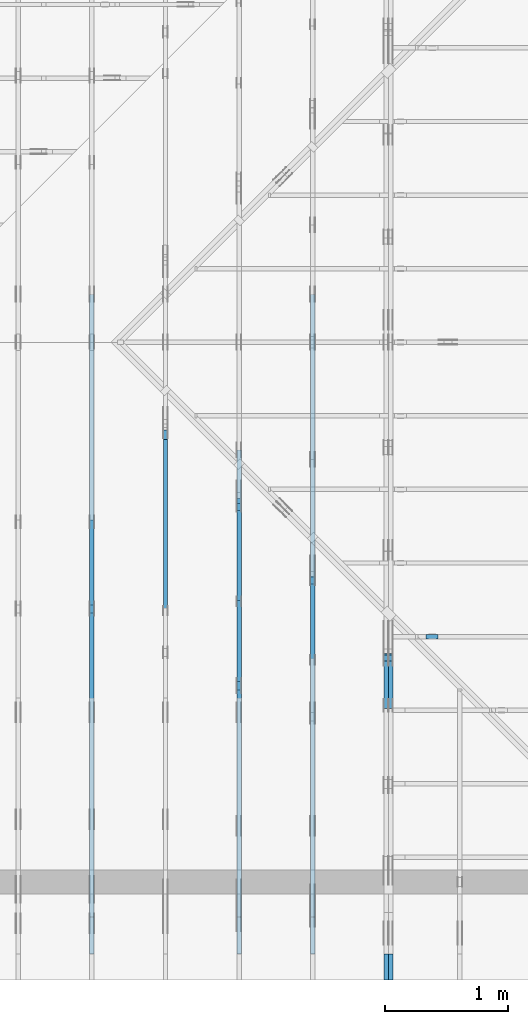
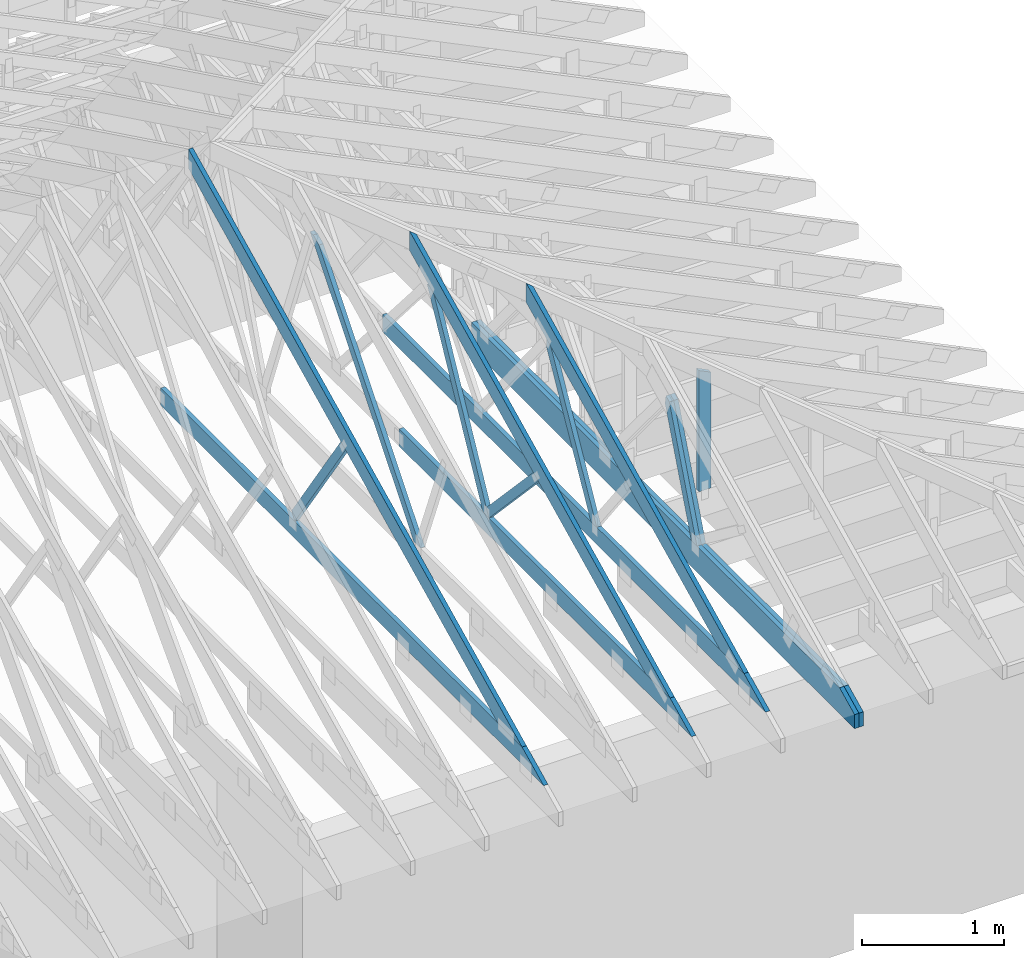
# One storey, part 29 of 159: 16 members, 6 elements without a shape of their own.
"""IFC2X3 building model written with IfcOpenShell, lengths in millimetres."""

from ifc_helpers import new_model, si_unit, frame, origin, origin_with_axes, origin_2d, place, context, project, spatial, faceted_brep, element, aggregate, save


model = new_model("IFC2X3")

# Units and contexts
model_context = context("Model", 3, precision=1e-05, world=origin())
plan_context = context("Plan", 2, precision=1e-05, world=origin_2d())
ifc_project = project(units=[si_unit("LENGTHUNIT", "METRE", prefix="MILLI"), si_unit("AREAUNIT", "SQUARE_METRE"), si_unit("VOLUMEUNIT", "CUBIC_METRE"), si_unit("SOLIDANGLEUNIT", "STERADIAN"), si_unit("PLANEANGLEUNIT", "RADIAN"), si_unit("MASSUNIT", "GRAM"), si_unit("TIMEUNIT", "SECOND"), si_unit("THERMODYNAMICTEMPERATUREUNIT", "DEGREE_CELSIUS"), si_unit("LUMINOUSINTENSITYUNIT", "LUMEN")], contexts=[model_context, plan_context])

# Site, building, storey
site_placement = place(None, origin_with_axes())
site = spatial("IfcSite", under=ifc_project, at=site_placement, CompositionType="ELEMENT")
building_placement = place(site_placement, origin_with_axes())
building = spatial("IfcBuilding", under=site, at=building_placement, Name="Plan 1", CompositionType="ELEMENT")
storey_placement = place(building_placement, origin_with_axes())
storey = spatial("IfcBuildingStorey", under=building, at=storey_placement, Name="Etasje 1", CompositionType="ELEMENT", Elevation=0.0)

# Assembly, member
assembly_1_placement = place(storey_placement, frame((16311.022261404749, -699.9989301294839, 1.1021457184401395e-15), z_axis=(1.0, -6.123031769111886e-17, 6.123031769111886e-17), x_axis=(6.123031769111886e-17, 1.0, 0.0)))
assembly_1 = element("IfcElementAssembly", 1, at=assembly_1_placement, inside=storey, Name="V8 (33)", AssemblyPlace="FACTORY", PredefinedType="TRUSS")
member_1_placement = place(assembly_1_placement, frame((4476.480509805102, 2189.4895238358513, -36.0), z_axis=(0.0, 0.0, 1.0), x_axis=(-0.6357240016981588, -0.7719164421521797, 0.0)))
member_1 = element("IfcMember", 2, at=member_1_placement, Name="V8-D11", context=model_context, shape_type="Brep", body=[
    faceted_brep([(2295.6910328957492, 73.00002724191063, 36.0), (0.0, 73.00002724191063, 36.0), (30.060308752172205, 36.5000129350874, 36.0), (110.05477702588541, 8.645112211524975e-05, 36.0), (2355.8113399879844, 8.645112211524975e-05, 36.0), (0.0, 73.00002724191063, 0.0), (2295.6910328957492, 73.00002724191063, 2.8113178252971904e-13), (2355.8113399879844, 8.645112211524975e-05, 2.8849415353560944e-13), (110.05477702588541, 8.645112211524975e-05, 1.3477377921440427e-14), (30.060308752172205, 36.5000129350874, 3.68120450957725e-15), (30.060242122563075, 36.50000000000318, -7.888609052210118e-31), (30.06024212256308, 36.50000000000319, 36.0), (8.950125995710323e-05, 73.00000000001138, 36.0), (8.950125995710323e-05, 73.00000000001138, -1.5777218104420236e-30), (110.05486615064636, 9.968914582714206e-12, 2.7610131682735413e-30), (110.05486615064636, 9.968914582714206e-12, 36.0), (30.06024212256306, 36.500000000003176, 36.0), (30.06024212256306, 36.500000000003176, 7.888609052210118e-31), (2355.811360573849, 1.6924518967404314e-12, -1.0362936731435327e-28), (2355.811360573849, 1.6946561881773117e-12, 36.0), (110.05486615064638, 1.0085711156000963e-11, 36.0), (110.05486615064638, 1.0083506864564083e-11, -4.84118395043281e-30), (2295.6910553312528, 73.00000000000455, 0.0), (2295.6910553312528, 73.00000000000455, 36.0), (2355.8113605738495, 0.0, 36.0), (2355.8113605738495, 0.0, 1.262177448353619e-29), (8.950125993578695e-05, 73.00000000001137, 0.0), (8.950125993578695e-05, 73.00000000001137, 36.0), (2295.6910553312523, 73.0000000000046, 36.0), (2295.6910553312523, 73.0000000000046, 3.1554436208840472e-30)], [[[0, 1, 2, 3, 4]], [[5, 6, 7, 8, 9]], [[10, 11, 12, 13]], [[14, 15, 16, 17]], [[18, 19, 20, 21]], [[22, 23, 24, 25]], [[26, 27, 28, 29]]]),
])
aggregate(assembly_1, [member_1])

# Assembly, members
assembly_2_placement = place(storey_placement, frame((18074.541652722903, -699.9989301294845, 4.408582873760558e-15), z_axis=(-1.0, 1.836909530733566e-16, 6.123031769111886e-17), x_axis=(-1.836909530733566e-16, -1.0, 0.0)))
assembly_2 = element("IfcElementAssembly", 3, at=assembly_2_placement, inside=storey, Name="V5 (30)", AssemblyPlace="FACTORY", PredefinedType="TRUSS")
member_2_placement = place(assembly_2_placement, frame((2.1736789885403288e-14, 222.99999999999997, -36.0), z_axis=(0.0, 0.0, 1.0), x_axis=(-1.0, 1.2246063538223773e-16, 0.0)))
member_2 = element("IfcMember", 4, at=member_2_placement, Name="V5-U2", context=model_context, shape_type="Brep", body=[
    faceted_brep([(5380.0, 223.00000000000125, 36.0), (0.0, 223.00000000000125, 36.0), (2.876229701544728e-05, 102.99998474121091, 36.0), (211.1812896728516, 0.0, 36.0), (5380.0, 0.0, 36.0), (0.0, 223.00000000000125, 0.0), (5380.0, 223.00000000000125, 6.58838218356439e-13), (5380.0, 0.0, 6.58838218356439e-13), (211.1812896728516, 0.0, 2.5861394914177804e-14), (2.876229701544728e-05, 102.99998474121091, 3.522249167564314e-21), (2.8762297051813242e-05, 102.9999859710806, -2.5591602876158762e-30), (2.8762297054017533e-05, 102.9999859710806, 36.0), (9.269391217049325e-14, 223.00000000001455, 36.0), (9.048962073361297e-14, 223.00000000001455, -5.540707857007639e-30), (211.18129568360746, -7.105427357601002e-14, 4.733165431326071e-30), (211.18129568360746, -7.105427357601002e-14, 36.0), (2.876229702053479e-05, 102.9999859710806, 36.0), (2.876229702053479e-05, 102.9999859710806, -1.5777218104420236e-30), (5380.0, -1.039350988528013e-12, 1.4021168432107416e-28), (5380.0, -1.0371466970911327e-12, 36.0), (211.1812956836075, -8.768146303186246e-14, 36.0), (211.1812956836075, -8.988575446874274e-14, 5.5037333020270255e-30), (5380.0, 223.00000000000125, 0.0), (5380.0, 223.00000000000125, 36.0), (5380.0, 1.2505552149377763e-12, 36.0), (5380.0, 1.2505552149377763e-12, 0.0), (0.0, 223.00000000001452, 0.0), (0.0, 223.00000000001452, 36.0), (5380.0, 223.00000000000105, 36.0), (5380.0, 223.00000000000105, -1.262177448353619e-29)], [[[0, 1, 2, 3, 4]], [[5, 6, 7, 8, 9]], [[10, 11, 12, 13]], [[14, 15, 16, 17]], [[18, 19, 20, 21]], [[22, 23, 24, 25]], [[26, 27, 28, 29]]]),
])
member_3_placement = place(assembly_2_placement, frame((2.1736789885403288e-14, 222.99999999999997, -72.0), z_axis=(0.0, 0.0, 1.0), x_axis=(-1.0, 1.2246063538223773e-16, 0.0)))
member_3 = element("IfcMember", 5, at=member_3_placement, Name="V5-U2", context=model_context, shape_type="Brep", body=[
    faceted_brep([(5380.0, 223.00000000000125, 36.0), (0.0, 223.00000000000125, 36.0), (2.876229701544728e-05, 102.99998474121091, 36.0), (211.1812896728516, 0.0, 36.0), (5380.0, 0.0, 36.0), (0.0, 223.00000000000125, 0.0), (5380.0, 223.00000000000125, 6.58838218356439e-13), (5380.0, 0.0, 6.58838218356439e-13), (211.1812896728516, 0.0, 2.5861394914177804e-14), (2.876229701544728e-05, 102.99998474121091, 3.522249167564314e-21), (2.8762297051813242e-05, 102.9999859710806, -2.5591602876158762e-30), (2.8762297054017533e-05, 102.9999859710806, 36.0), (9.269391217049325e-14, 223.00000000001455, 36.0), (9.048962073361297e-14, 223.00000000001455, -5.540707857007639e-30), (211.18129568360746, -7.105427357601002e-14, 4.733165431326071e-30), (211.18129568360746, -7.105427357601002e-14, 36.0), (2.876229702053479e-05, 102.9999859710806, 36.0), (2.876229702053479e-05, 102.9999859710806, -1.5777218104420236e-30), (5380.0, -1.039350988528013e-12, 1.4021168432107416e-28), (5380.0, -1.0371466970911327e-12, 36.0), (211.1812956836075, -8.768146303186246e-14, 36.0), (211.1812956836075, -8.988575446874274e-14, 5.5037333020270255e-30), (5380.0, 223.00000000000125, 0.0), (5380.0, 223.00000000000125, 36.0), (5380.0, 1.2505552149377763e-12, 36.0), (5380.0, 1.2505552149377763e-12, 0.0), (0.0, 223.00000000001452, 0.0), (0.0, 223.00000000001452, 36.0), (5380.0, 223.00000000000105, 36.0), (5380.0, 223.00000000000105, -1.262177448353619e-29)], [[[0, 1, 2, 3, 4]], [[5, 6, 7, 8, 9]], [[10, 11, 12, 13]], [[14, 15, 16, 17]], [[18, 19, 20, 21]], [[22, 23, 24, 25]], [[26, 27, 28, 29]]]),
])
member_4_placement = place(assembly_2_placement, frame((-2684.061344967092, 1234.6539427070286, -36.0), z_axis=(0.0, 0.0, 1.0), x_axis=(0.3612308951570343, -0.9324764020521097, 0.0)))
member_4 = element("IfcMember", 6, at=member_4_placement, Name="V5-D49", context=model_context, shape_type="Brep", body=[
    faceted_brep([(1113.1904093851324, 72.99997145557336, 36.0), (39.38304744955349, 72.99997145557336, 36.0), (3.093136592724477e-05, 36.50007100723906, 36.0), (62.15337691077502, 6.271424354054034e-06, 36.0), (1084.9110395508906, 6.271424354054034e-06, 36.0), (39.38304744955349, 72.99997145557336, 4.822873013961137e-15), (1113.1904093851324, 72.99997145557336, 1.3632200483471663e-13), (1084.9110395508906, 6.271424354054034e-06, 1.328588952366061e-13), (62.15337691077502, 6.271424354054034e-06, 7.611342027645214e-15), (3.093136592724477e-05, 36.50007100723906, 3.787874724690893e-21), (3.552713678800501e-15, 36.50007580493252, -1.9721522630525295e-31), (3.552713678800501e-15, 36.50007580493252, 36.0), (39.383046750819176, 73.00007580384158, 36.0), (39.383046750819176, 73.00007580384158, 1.9721522630525295e-31), (62.15334871027564, 7.58038409109929e-05, -7.888609052210118e-31), (62.15334871027564, 7.580384091454562e-05, 36.0), (-3.552713678800501e-15, 36.50007580493251, 36.0), (-5.329070518200751e-15, 36.50007580493251, 1.1832913578315177e-30), (1084.9110689164472, 7.580383888439785e-05, 1.205915918926653e-29), (1084.9110689164472, 7.580383888660214e-05, 36.0), (62.15334871027562, 7.580384089125615e-05, 36.0), (62.15334871027562, 7.580384088905186e-05, 6.908558974923909e-31), (1113.1904498084798, 73.00007580383908, 1.4070658146423997e-29), (1113.1904498084798, 73.00007580383908, 36.0), (1084.9110689164474, 7.580383902450194e-05, 36.0), (1084.9110689164474, 7.580383902450194e-05, 1.3829420280233085e-29), (39.38304675081918, 73.00007580384158, -7.888609052210118e-31), (39.38304675081918, 73.00007580384158, 36.0), (1113.1904498084796, 73.00007580383912, 36.0), (1113.1904498084796, 73.00007580383912, 3.1554436208840472e-30)], [[[0, 1, 2, 3, 4]], [[5, 6, 7, 8, 9]], [[10, 11, 12, 13]], [[14, 15, 16, 17]], [[18, 19, 20, 21]], [[22, 23, 24, 25]], [[26, 27, 28, 29]]]),
])
member_5_placement = place(assembly_2_placement, frame((-2684.061344967092, 1234.6539427070286, -72.0), z_axis=(0.0, 0.0, 1.0), x_axis=(0.3612308951570343, -0.9324764020521097, 0.0)))
member_5 = element("IfcMember", 7, at=member_5_placement, Name="V5-D49", context=model_context, shape_type="Brep", body=[
    faceted_brep([(1113.1904093851324, 72.99997145557336, 36.0), (39.38304744955349, 72.99997145557336, 36.0), (3.093136592724477e-05, 36.50007100723906, 36.0), (62.15337691077502, 6.271424354054034e-06, 36.0), (1084.9110395508906, 6.271424354054034e-06, 36.0), (39.38304744955349, 72.99997145557336, 4.822873013961137e-15), (1113.1904093851324, 72.99997145557336, 1.3632200483471663e-13), (1084.9110395508906, 6.271424354054034e-06, 1.328588952366061e-13), (62.15337691077502, 6.271424354054034e-06, 7.611342027645214e-15), (3.093136592724477e-05, 36.50007100723906, 3.787874724690893e-21), (3.552713678800501e-15, 36.50007580493252, -1.9721522630525295e-31), (3.552713678800501e-15, 36.50007580493252, 36.0), (39.383046750819176, 73.00007580384158, 36.0), (39.383046750819176, 73.00007580384158, 1.9721522630525295e-31), (62.15334871027564, 7.58038409109929e-05, -7.888609052210118e-31), (62.15334871027564, 7.580384091454562e-05, 36.0), (-3.552713678800501e-15, 36.50007580493251, 36.0), (-5.329070518200751e-15, 36.50007580493251, 1.1832913578315177e-30), (1084.9110689164472, 7.580383888439785e-05, 1.205915918926653e-29), (1084.9110689164472, 7.580383888660214e-05, 36.0), (62.15334871027562, 7.580384089125615e-05, 36.0), (62.15334871027562, 7.580384088905186e-05, 6.908558974923909e-31), (1113.1904498084798, 73.00007580383908, 1.4070658146423997e-29), (1113.1904498084798, 73.00007580383908, 36.0), (1084.9110689164474, 7.580383902450194e-05, 36.0), (1084.9110689164474, 7.580383902450194e-05, 1.3829420280233085e-29), (39.38304675081918, 73.00007580384158, -7.888609052210118e-31), (39.38304675081918, 73.00007580384158, 36.0), (1113.1904498084796, 73.00007580383912, 36.0), (1113.1904498084796, 73.00007580383912, 3.1554436208840472e-30)], [[[0, 1, 2, 3, 4]], [[5, 6, 7, 8, 9]], [[10, 11, 12, 13]], [[14, 15, 16, 17]], [[18, 19, 20, 21]], [[22, 23, 24, 25]], [[26, 27, 28, 29]]]),
])
aggregate(assembly_2, [member_2, member_3, member_4, member_5])

assembly_3_placement = place(storey_placement, frame((17475.02226140475, -699.9989301294827, 1.1021457184401395e-15), z_axis=(-1.0, 1.836909530733566e-16, 6.123031769111886e-17), x_axis=(-1.836909530733566e-16, -1.0, 0.0)))
assembly_3 = element("IfcElementAssembly", 8, at=assembly_3_placement, inside=storey, Name="V6 (31)", AssemblyPlace="FACTORY", PredefinedType="TRUSS")
member_6_placement = place(assembly_3_placement, frame((-3638.957688131659, 1730.1731640099995, -36.000000217579895), z_axis=(0.0, 0.0, 1.0), x_axis=(0.8987940462991668, -0.4383711467890778, 0.0)))
member_6 = element("IfcMember", 9, at=member_6_placement, Name="V6-O33", context=model_context, shape_type="Brep", body=[
    faceted_brep([(112.23814021505615, 1.0301732906725647e-06, 2.2533632630938882e-06), (72.18447321771511, 6.723111589224118e-06, 35.99999718740396), (4.92666358766769e-05, 148.00000153981878, 36.00000021757989), (40.05371920917153, 148.0000018609984, 2.842170943040401e-14), (3100.5077145615314, 1.5405398645785285e-06, 2.1757988832860065e-07), (3100.5077145615314, 1.5405396429618581e-06, 36.00000021757989), (72.18447237403143, 1.5405401992374406e-06, 36.00000021757989), (112.23814134986151, 1.5405404134966144e-06, 2.1757988832860065e-07), (40.0537168771325, 148.00000154053293, 2.1757989323360425e-07), (3403.9527418405114, 148.00000154053293, 2.1758030517881621e-07), (3100.5079176217614, 1.5399753010569839e-06, 2.1758026801877024e-07), (112.23814223113641, 1.5399753010569839e-06, 2.1757990207335486e-07), (5.014789849155932e-05, 148.00000153983194, 36.00000021757989), (3403.9528890456036, 148.00000153983174, 36.00000021757989), (3403.9528890456036, 148.00000153983174, 2.1757988832860065e-07), (40.05371912372857, 148.00000153983194, 2.1757988832860065e-07), (3403.9527810557133, 148.0000015409405, 2.1757988832860065e-07), (3403.9527810557133, 148.0000015409405, 36.00000021757989), (3100.5078093425827, 2.2737367544323206e-13, 36.00000021757989), (3100.5078093425827, 2.2737367544323206e-13, 2.1757988832860065e-07), (3403.9527893066406, 148.00000153997533, 36.00000021757989), (0.0, 148.00000153997533, 36.00000021757989), (72.1845703125, 1.540540438327298e-06, 36.00000021757989), (3100.5078125, 1.540540438327298e-06, 36.00000021757989)], [[[0, 1, 2, 3]], [[4, 5, 6, 7]], [[8, 9, 10, 11]], [[12, 13, 14, 15]], [[16, 17, 18, 19]], [[20, 21, 22, 23]]]),
])
member_7_placement = place(assembly_3_placement, frame((-211.18128967285153, 370.99999999999994, -36.0), z_axis=(0.0, 0.0, 1.0), x_axis=(-1.0, 1.2246063538223773e-16, 0.0)))
member_7 = element("IfcMember", 10, at=member_7_placement, Name="V6-U32", context=model_context, shape_type="Brep", body=[
    faceted_brep([(5379.999862670898, 148.00000000000063, 36.0), (0.0, 148.00000000000063, 36.0), (303.4449920654297, 0.0, 36.0), (5379.999862670898, 0.0, 36.0), (0.0, 148.00000000000063, 0.0), (5379.999862670898, 148.00000000000063, 6.588382015390299e-13), (5379.999862670898, 0.0, 6.588382015390299e-13), (303.4449920654297, 0.0, 3.7160066531890605e-14), (303.4449745621532, 1.4210854715202004e-14, -1.5777218104420236e-30), (303.4449745621532, 1.4210854715202004e-14, 36.0), (6.007030613375264e-06, 147.99999999999994, 36.0), (6.007030613375264e-06, 147.99999999999994, 0.0), (5380.000006007031, -1.059610016307478e-12, 1.3797161043262737e-28), (5380.000006007031, -1.0574057248705977e-12, 36.0), (303.4449745621532, -1.2488849281514447e-13, 36.0), (303.4449745621532, -1.2709278425202475e-13, 7.781931556000303e-30), (5380.000006007031, 148.0000000000012, 0.0), (5380.000006007031, 148.0000000000012, 36.0), (5380.000006007031, 1.1937117960769683e-12, 36.0), (5380.000006007031, 1.1937117960769683e-12, 0.0), (6.0070306062698364e-06, 147.99999999999997, 0.0), (6.0070306062698364e-06, 147.99999999999997, 36.0), (5380.000006007031, 148.00000000000082, 36.0), (5380.000006007031, 148.00000000000082, -2.0510383535746307e-29)], [[[0, 1, 2, 3]], [[4, 5, 6, 7]], [[8, 9, 10, 11]], [[12, 13, 14, 15]], [[16, 17, 18, 19]], [[20, 21, 22, 23]]]),
])
member_8_placement = place(assembly_3_placement, frame((-3317.431413361298, 1540.0392075687062, -36.00000000000001), z_axis=(0.0, 0.0, 1.0), x_axis=(0.48666532050397915, -0.8735884991337508, 0.0)))
member_8 = element("IfcMember", 11, at=member_8_placement, Name="V6-D35", context=model_context, shape_type="Brep", body=[
    faceted_brep([(1378.87089669229, 72.99996131865464, 36.0), (52.363663621895284, 72.99996131865464, 36.0), (1.2525784768513404e-05, 36.50001933496242, 36.0), (54.103403123413045, 0.00010201729492109735, 36.0), (1338.2035694033498, 0.00010201729492109735, 36.0), (52.363663621895284, 72.99996131865464, 6.412487518079064e-15), (1378.87089669229, 72.99996131865464, 1.6885740611901372e-13), (1338.2035694033498, 0.00010201729492109735, 1.6387725937991269e-13), (54.103403123413045, 0.00010201729492109735, 6.625537122834506e-15), (1.2525784768513404e-05, 36.50001933496242, 1.533915561413307e-21), (0.0, 36.50000000031013, -3.944304526105059e-31), (0.0, 36.50000000031013, 36.0), (52.36365352476241, 72.99999999999997, 36.0), (52.36365352476241, 72.99999999999997, -7.888609052210118e-31), (54.10340770873154, -1.4210854715202004e-14, 5.1244436530635555e-31), (54.10340770873154, -1.0658141036401503e-14, 36.0), (0.0, 36.500000000310145, 36.0), (0.0, 36.50000000031014, -2.6862469566280085e-31), (1338.2035234299951, 9.0442757405462e-13, 3.1026183997348555e-31), (1338.2035234299951, 9.066318654915003e-13, 36.0), (54.10340770873154, 1.9994280718869188e-15, 36.0), (54.10340770873154, -2.0486336499336028e-16, 1.254384892181493e-32), (1378.8709182411892, 73.00000000000205, -1.262177448353619e-29), (1378.8709182411892, 73.00000000000205, 36.0), (1338.203523429995, 1.1368683772161603e-12, 36.0), (1338.203523429995, 1.1368683772161603e-12, -2.524354896707238e-29), (52.36365352476241, 73.0, -7.888609052210118e-31), (52.36365352476241, 73.0, 36.0), (1378.8709182411894, 73.00000000000168, 36.0), (1378.8709182411894, 73.00000000000168, -8.67746995743113e-30)], [[[0, 1, 2, 3, 4]], [[5, 6, 7, 8, 9]], [[10, 11, 12, 13]], [[14, 15, 16, 17]], [[18, 19, 20, 21]], [[22, 23, 24, 25]], [[26, 27, 28, 29]]]),
])
aggregate(assembly_3, [member_6, member_7, member_8])

assembly_4_placement = place(storey_placement, frame((16875.02226140475, -699.9989301294827, 1.1021457184401395e-15), z_axis=(-1.0, 1.836909530733566e-16, 6.123031769111886e-17), x_axis=(-1.836909530733566e-16, -1.0, 0.0)))
assembly_4 = element("IfcElementAssembly", 12, at=assembly_4_placement, inside=storey, Name="V7 (32)", AssemblyPlace="FACTORY", PredefinedType="TRUSS")
member_9_placement = place(assembly_4_placement, frame((-4238.957643851983, 2022.812695551967, -36.00000021758315), z_axis=(0.0, 0.0, 1.0), x_axis=(0.8987940462991668, -0.4383711467890778, 0.0)))
member_9 = element("IfcMember", 13, at=member_9_placement, Name="V7-O22", context=model_context, shape_type="Brep", body=[
    faceted_brep([(112.23809094844356, 1.0322122605543882e-06, 2.253338998059462e-06), (72.18442395110651, 6.725138682384113e-06, 35.99999718738281), (7.105427357601002e-15, 148.0000015418327, 36.00000021758318), (40.053669942532004, 148.00000186302393, 2.1316282072803006e-14), (3768.0689445917715, 1.5425536533801854e-06, 2.1758314971975778e-07), (3768.0689445917715, 1.5425531999489475e-06, 36.00000021758315), (72.18442310739647, 1.5425538788494976e-06, 36.00000021758315), (112.23809208322655, 1.542554324923239e-06, 2.1758314971975778e-07), (40.053667610492994, 148.00000154254366, 2.1758315462475538e-07), (4071.513971870747, 148.00000154254366, 2.1758364831994575e-07), (3768.068903511372, 1.5416081282637606e-06, 2.1758361115986986e-07), (112.2380929644969, 1.5416081282637606e-06, 2.1758316346450597e-07), (8.812685337034054e-07, 148.0000015418238, 36.00000021758316), (4071.5138749352236, 148.00000154182354, 36.00000021758316), (4071.5138749352236, 148.00000154182376, 2.1758314971975776e-07), (40.05366985709861, 148.00000154182402, 2.1758314971975776e-07), (4071.513896073102, 148.00000154093982, 2.1758314971975778e-07), (4071.513896073102, 148.00000154093982, 36.00000021758315), (3768.0689243599704, -4.547473508864641e-13, 36.00000021758315), (3768.0689243599704, -4.547473508864641e-13, 2.1758314971975778e-07), (4071.5139043273766, 148.0000015416084, 36.00000021758315), (7.986448599694995e-05, 148.0000015416084, 36.00000021758315), (72.184406036361, 1.5425541164404422e-06, 36.00000021758315), (3768.068927520736, 1.5425541164404422e-06, 36.00000021758315)], [[[0, 1, 2, 3]], [[4, 5, 6, 7]], [[8, 9, 10, 11]], [[12, 13, 14, 15]], [[16, 17, 18, 19]], [[20, 21, 22, 23]]]),
])
member_10_placement = place(assembly_4_placement, frame((-211.18128967285153, 371.00000000093127, -36.0), z_axis=(0.0, 0.0, 1.0), x_axis=(-1.0, 1.2246063538223773e-16, 0.0)))
member_10 = element("IfcMember", 14, at=member_10_placement, Name="V7-U37", context=model_context, shape_type="Brep", body=[
    faceted_brep([(4108.817733764648, 148.0000000009318, 36.0), (0.0, 148.0000000009318, 36.0), (303.4449920654297, 9.313225746154785e-10, 36.0), (4108.817733764648, 9.313225746154785e-10, 36.0), (0.0, 148.0000000009318, 0.0), (4108.817733764648, 148.0000000009318, 5.031684303466249e-13), (4108.817733764648, 9.313225746154785e-10, 5.031684303466249e-13), (303.4449920654297, 9.313225746154785e-10, 3.7160066531890605e-14), (303.4449745640158, -4.263256414560601e-14, 4.733165431326071e-30), (303.4449745640158, -4.263256414560601e-14, 36.0), (6.01075591788458e-06, 148.00000000093132, 36.0), (6.01075591788458e-06, 148.00000000093132, -3.1554436208840472e-30), (4108.817634301056, 9.32132175692924e-10, 6.116518352884973e-30), (4108.817634301056, 9.32134379984361e-10, 36.0), (303.44497456401587, -5.173066477501427e-15, 36.0), (303.44497456401587, -7.377357914381706e-15, 4.517179688187166e-31), (4108.817634301056, 148.00000000093226, 0.0), (4108.817634301056, 148.00000000093226, 36.0), (4108.817634301056, 9.322320693172514e-10, 36.0), (4108.817634301056, 9.322320693172514e-10, 0.0), (6.010755896568298e-06, 148.0000000009313, 0.0), (6.010755896568298e-06, 148.0000000009313, 36.0), (4108.817634301056, 148.00000000093195, 36.0), (4108.817634301056, 148.00000000093195, -1.735493991486226e-29)], [[[0, 1, 2, 3]], [[4, 5, 6, 7]], [[8, 9, 10, 11]], [[12, 13, 14, 15]], [[16, 17, 18, 19]], [[20, 21, 22, 23]]]),
])
member_11_placement = place(assembly_4_placement, frame((-3926.8689494893006, 1850.4420449067761, -36.0), z_axis=(0.0, 0.0, 1.0), x_axis=(0.46885659839797056, -0.8832743006216609, 0.0)))
member_11 = element("IfcMember", 15, at=member_11_placement, Name="V7-D20", context=model_context, shape_type="Brep", body=[
    faceted_brep([(1713.7015738069842, 72.9999626512149, 36.0), (69.53930275152379, 72.9999626512149, 36.0), (19.374839086726297, 36.500007032525446, 36.0), (4.985297664461541e-05, 3.3546802569617284e-05, 36.0), (1674.9519953394847, 3.3546802569617284e-05, 36.0), (69.53930275152379, 72.9999626512149, 8.515827198989395e-15), (1713.7015738069842, 72.9999626512149, 2.0986098358394406e-13), (1674.9519953394847, 3.3546802569617284e-05, 2.0511568558402018e-13), (4.985297664461541e-05, 3.3546802569617284e-05, 6.105027195595461e-21), (19.374839086726297, 36.500007032525446, 2.3726551049891168e-15), (19.374803309383417, 36.50000000267164, 3.944304526105059e-31), (19.374803309383417, 36.50000000267164, 36.0), (69.53924562809287, 73.00000000000045, 36.0), (69.53924562809287, 73.00000000000045, 0.0), (8.563404245295336e-17, 9.094492458077504e-13, -5.936320824549069e-33), (2.0326280197297004e-15, 9.084157492227769e-13, 36.0), (19.37480330938343, 36.500000002671634, 36.0), (19.374803309383427, 36.500000002671634, -3.2278585867929512e-31), (1674.9519870156519, -8.858350339752355e-13, 5.423996055222675e-29), (1674.9519870156519, -8.836307425383553e-13, 36.0), (2.3627124798588217e-30, 9.116989932098085e-13, 36.0), (0.0, 9.094947017729282e-13, 0.0), (1713.7015936315743, 73.00000000000011, -1.7970986810656837e-29), (1713.7015936315743, 73.00000000000011, 36.0), (1674.9519870156519, 1.1368683772161603e-13, 36.0), (1674.9519870156519, 1.1368683772161603e-13, -1.7461635146409176e-29), (69.53924562809289, 73.00000000000045, -7.888609052210118e-31), (69.53924562809289, 73.00000000000044, 36.0), (1713.7015936315743, 72.99999999999999, 36.0), (1713.7015936315743, 72.99999999999999, -1.5777218104420236e-30)], [[[0, 1, 2, 3, 4]], [[5, 6, 7, 8, 9]], [[10, 11, 12, 13]], [[14, 15, 16, 17]], [[18, 19, 20, 21]], [[22, 23, 24, 25]], [[26, 27, 28, 29]]]),
])
member_12_placement = place(assembly_4_placement, frame((-2418.4511346082118, 1158.9470690353523, -36.0), z_axis=(0.0, 0.0, 1.0), x_axis=(-0.684897752407618, -0.7286391896864959, 0.0)))
member_12 = element("IfcMember", 16, at=member_12_placement, Name="V7-D51", context=model_context, shape_type="Brep", body=[
    faceted_brep([(1012.7777239066806, 72.99998982285842, 36.0), (6.779756893138256e-05, 72.99998982285842, 36.0), (22.635803724592733, 0.0, 36.0), (987.908865008025, 0.0, 36.0), (6.779756893138256e-05, 72.99998982285842, 8.302533368708168e-21), (1012.7777239066806, 72.99998982285842, 1.2402540357058865e-13), (987.908865008025, 0.0, 1.2097994730862805e-13), (22.635803724592733, 0.0, 2.7719949065012494e-15), (22.63576821180038, 2.063298052057405e-05, 1.9721522630525295e-31), (22.635768211800382, 2.063298052146223e-05, 36.0), (2.842170943040401e-14, 73.00002063298052, 36.0), (2.4868995751603507e-14, 73.00002063298052, -1.3805065841367707e-30), (987.9089334671846, 2.0632978617993318e-05, 3.3071415430158557e-29), (987.9089334671846, 2.063297862019761e-05, 36.0), (22.635768211800382, 2.063298051217915e-05, 36.0), (22.635768211800382, 2.0632980509974857e-05, 7.577590174101193e-31), (1012.7776949452191, 73.00002063298007, 1.262177448353619e-29), (1012.7776949452191, 73.00002063298007, 36.0), (987.9089334671849, 2.0632979158108355e-05, 36.0), (987.9089334671849, 2.0632979158108355e-05, 0.0), (0.0, 73.00002063298052, 0.0), (0.0, 73.00002063298052, 36.0), (1012.7776949452189, 73.00002063298001, 36.0), (1012.7776949452189, 73.00002063298001, -3.944304526105059e-30)], [[[0, 1, 2, 3]], [[4, 5, 6, 7]], [[8, 9, 10, 11]], [[12, 13, 14, 15]], [[16, 17, 18, 19]], [[20, 21, 22, 23]]]),
])
aggregate(assembly_4, [member_9, member_10, member_11, member_12])

# Assembly, member
assembly_5_placement = place(storey_placement, frame((21100.012663101486, 2118.007401421258, 1.1021457184401395e-15), z_axis=(1.2246063538223773e-16, 1.0, 6.123031769111886e-17), x_axis=(-1.0, 1.2246063538223773e-16, 0.0)))
assembly_5 = element("IfcElementAssembly", 17, at=assembly_5_placement, inside=storey, Name="S17 (37)", AssemblyPlace="FACTORY", PredefinedType="TRUSS")
member_13_placement = place(assembly_5_placement, frame((2583.094643307137, 1262.9921875, -36.0), z_axis=(0.0, 0.0, 1.0), x_axis=(-1.836909530733566e-16, -1.0, 0.0)))
member_13 = element("IfcMember", 18, at=member_13_placement, Name="S17-S9", context=model_context, shape_type="Brep", body=[
    faceted_brep([(1039.9921875, 98.00008325536328, 36.0), (0.0, 98.00008325536328, 36.0), (47.7978515625, 8.325536327902228e-05, 36.0), (1039.9921875, 8.325536327902228e-05, 36.0), (0.0, 98.00008325536328, 0.0), (1039.9921875, 98.00008325536328, 1.273581040738133e-13), (1039.9921875, 8.325536327902228e-05, 1.273581040738133e-13), (47.7978515625, 8.325536327902228e-05, 5.853355272249634e-15), (47.79783779839636, 1.4548362514688051e-11, 0.0), (47.79783779839636, 1.4548362514688051e-11, 36.0), (4.411894046540965e-05, 97.99999999999957, 36.0), (4.411894046540965e-05, 97.99999999999957, -2.7610131682735413e-30), (1039.992187500124, -6.409764103942921e-13, 3.924718924095545e-29), (1039.992187500124, -6.387721189574118e-13, 36.0), (47.79783779839636, 1.4524660369182353e-11, 36.0), (47.79783779839636, 1.4522456077745473e-11, 1.8037931514576675e-30), (1039.992187500124, 98.0, 4.0515896092151166e-27), (1039.992187500124, 98.0, 36.0), (1039.992187500124, 0.0, 36.0), (1039.992187500124, 0.0, 0.0), (4.4118940422777086e-05, 97.99999999999955, 0.0), (4.4118940422777086e-05, 97.99999999999955, 36.0), (1039.9921875000578, 97.99999999999994, 36.0), (1039.9921875000578, 97.99999999999994, -3.1554436208840472e-30)], [[[0, 1, 2, 3]], [[4, 5, 6, 7]], [[8, 9, 10, 11]], [[12, 13, 14, 15]], [[16, 17, 18, 19]], [[20, 21, 22, 23]]]),
])
aggregate(assembly_5, [member_13])

# Assembly, members
assembly_6_placement = place(storey_placement, frame((15675.02226140475, -699.9989301294845, 1.1021457184401395e-15), z_axis=(-1.0, 1.836909530733566e-16, 6.123031769111886e-17), x_axis=(-1.836909530733566e-16, -1.0, 0.0)))
assembly_6 = element("IfcElementAssembly", 19, at=assembly_6_placement, inside=storey, Name="T7 (111)", AssemblyPlace="FACTORY", PredefinedType="TRUSS")
member_14_placement = place(assembly_6_placement, frame((-5264.878447895178, 2523.1876964355156, -36.0), z_axis=(0.0, 0.0, 1.0), x_axis=(0.8987940462991668, -0.4383711467890778, 0.0)))
member_14 = element("IfcMember", 20, at=member_14_placement, Name="T7-O3", context=model_context, shape_type="Brep", body=[
    faceted_brep([(5212.95535395332, 148.00000154094027, 36.0), (0.0, 148.00000154094027, 36.0), (72.18440200989608, 5.7974317996922764e-05, 36.0), (4909.510382240189, 5.7974317996922764e-05, 36.0), (0.0, 148.00000154094027, 0.0), (5212.95535395332, 148.00000154094027, 6.383818248643616e-13), (4909.510382240189, 5.7974317996922764e-05, 6.012217608248263e-13), (72.18440200989608, 5.7974317996922764e-05, 8.839747734818752e-15), (72.18447769922204, 9.2140264804641e-06, -7.888609052210118e-31), (72.18447769922206, 9.2140264804641e-06, 36.0), (5.4591825588090614e-05, 148.00000921330525, 36.0), (5.4591825588090614e-05, 148.00000921330525, -7.888609052210118e-31), (4909.510401129447, 9.21290418597988e-06, 1.6550270895783706e-28), (4909.510401129447, 9.212904188184172e-06, 36.0), (72.18447769922204, 9.21402643937418e-06, 36.0), (72.18447769922204, 9.214026437169889e-06, 2.433384460947949e-30), (5212.955369681814, 148.00000921223887, 1.0605704288840677e-29), (5212.955369681814, 148.00000921223887, 36.0), (4909.510401129447, 9.212906661559828e-06, 36.0), (4909.510401129447, 9.212906661559828e-06, -1.359749288005947e-29), (5.459182557387976e-05, 148.00000921330525, 0.0), (5.459182557387976e-05, 148.00000921330525, 36.0), (5212.955369681813, 148.00000921223887, 36.0), (5212.955369681813, 148.00000921223887, 7.888609052210118e-30)], [[[0, 1, 2, 3]], [[4, 5, 6, 7]], [[8, 9, 10, 11]], [[12, 13, 14, 15]], [[16, 17, 18, 19]], [[20, 21, 22, 23]]]),
])
member_15_placement = place(assembly_6_placement, frame((-211.18128967285153, 370.99999999999994, -36.0), z_axis=(0.0, 0.0, 1.0), x_axis=(-1.0, 1.2246063538223773e-16, 0.0)))
member_15 = element("IfcMember", 21, at=member_15_placement, Name="T7-U32", context=model_context, shape_type="Brep", body=[
    faceted_brep([(5379.999862670898, 148.00000000000063, 36.0), (0.0, 148.00000000000063, 36.0), (303.4449920654297, 0.0, 36.0), (5379.999862670898, 0.0, 36.0), (0.0, 148.00000000000063, 0.0), (5379.999862670898, 148.00000000000063, 6.588382015390299e-13), (5379.999862670898, 0.0, 6.588382015390299e-13), (303.4449920654297, 0.0, 3.7160066531890605e-14), (303.44497456401575, -1.8474111129762605e-13, 1.4199496293978212e-29), (303.44497456401575, -1.8474111129762605e-13, 36.0), (6.010755903673726e-06, 148.0, 36.0), (6.010755903673726e-06, 148.0, -1.5777218104420236e-30), (5380.000006010756, -1.0494167752128893e-12, 1.2690585325561372e-28), (5380.000006010756, -1.047212483776009e-12, 36.0), (303.44497456401587, -1.146952517202135e-13, 36.0), (303.44497456401587, -1.1689954315709379e-13, 7.157796165455513e-30), (5380.000006010756, 148.000000000001, 0.0), (5380.000006010756, 148.000000000001, 36.0), (5380.000006010756, 1.0231815394945443e-12, 36.0), (5380.000006010756, 1.0231815394945443e-12, 0.0), (6.010755896568298e-06, 147.99999999999997, 0.0), (6.010755896568298e-06, 147.99999999999997, 36.0), (5380.000006010756, 148.00000000000082, 36.0), (5380.000006010756, 148.00000000000082, -9.466330862652142e-30)], [[[0, 1, 2, 3]], [[4, 5, 6, 7]], [[8, 9, 10, 11]], [[12, 13, 14, 15]], [[16, 17, 18, 19]], [[20, 21, 22, 23]]]),
])
member_16_placement = place(assembly_6_placement, frame((-3053.2314180439453, 1456.2901995043017, -36.00000000000001), z_axis=(0.0, 0.0, 1.0), x_axis=(-0.5642475050080044, -0.8256056886263821, 0.0)))
member_16 = element("IfcMember", 22, at=member_16_placement, Name="T7-D42", context=model_context, shape_type="Brep", body=[
    faceted_brep([(1264.6473178393353, 73.00019836058664, 36.0), (2.90698949356738e-06, 73.00019836058664, 36.0), (10.714657584819633, 4.511090492087533e-05, 36.0), (1236.186095030735, 4.511090492087533e-05, 36.0), (2.90698949356738e-06, 73.00019836058664, 3.5599178043175084e-22), (1264.6473178393353, 73.00019836058664, 1.5486951407704775e-13), (1236.186095030735, 4.511090492087533e-05, 1.5138413464815112e-13), (10.714657584819633, 4.511090492087533e-05, 1.3121237757401251e-15), (10.714685884898016, 0.00010020237868935133, 1.010048471493429e-31), (10.714685884898017, 0.00010020237868957338, 36.0), (3.375077994860476e-14, 73.00010020237825, 36.0), (3.197442310920451e-14, 73.00010020237825, -2.1820420316813824e-30), (1236.1860298820347, 0.00010020237954454694, 5.902699555591949e-29), (1236.1860298820347, 0.00010020237954675123, 36.0), (10.714685884898017, 0.00010020237868342204, 36.0), (10.714685884898017, 0.00010020237868121774, 5.116180235117775e-31), (1264.6473849240515, 73.00010020238051, 2.686871379716991e-29), (1264.6473849240515, 73.00010020238051, 36.0), (1236.1860298820352, 0.00010020238050856278, 36.0), (1236.1860298820352, 0.00010020238050856278, 2.662727280413415e-29), (0.0, 73.00010020237823, 0.0), (0.0, 73.00010020237823, 36.0), (1264.647384924051, 73.0001002023804, 36.0), (1264.647384924051, 73.00010020238041, -7.099748146989106e-30)], [[[0, 1, 2, 3]], [[4, 5, 6, 7]], [[8, 9, 10, 11]], [[12, 13, 14, 15]], [[16, 17, 18, 19]], [[20, 21, 22, 23]]]),
])
aggregate(assembly_6, [member_14, member_15, member_16])

save(model, "model.ifc")
